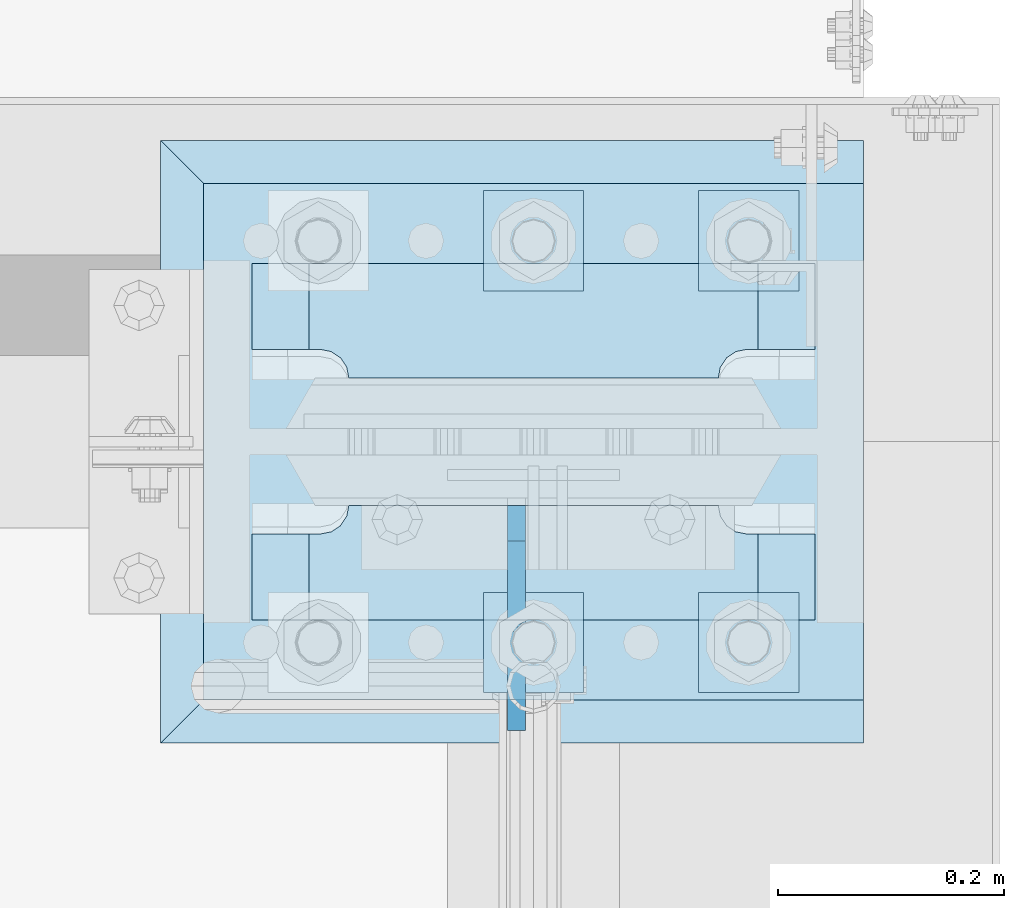
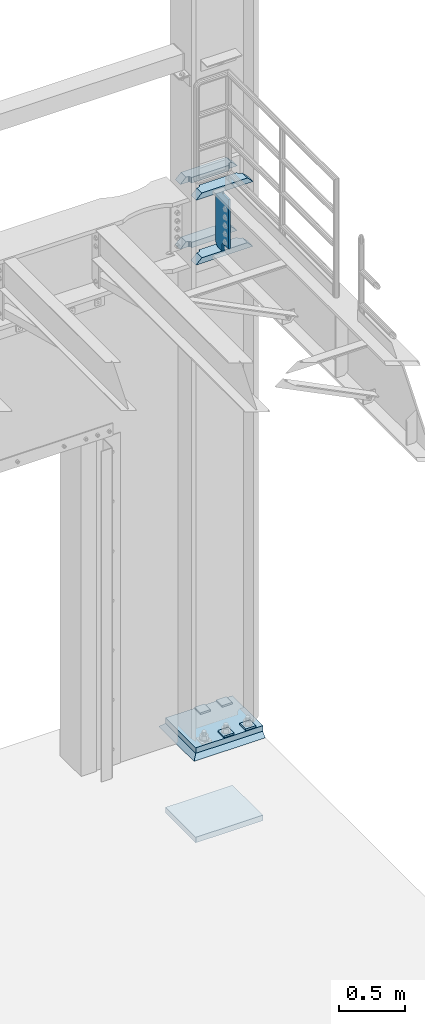
# One storey, part 1830 of 1876: 12 plates, 3 elements without a shape of their own.
"""IFC2X3 building model written with IfcOpenShell, lengths in millimetres."""

from ifc_helpers import new_model, si_unit, frame, origin_with_axes, place, context, subcontext, project, spatial, faceted_brep, material, type_object, element, aggregate, save


model = new_model("IFC2X3")

# Units and contexts
model_context = context("Model", 3, precision=1e-05, world=origin_with_axes())
body_context = subcontext(model_context, "Body", "Model", "MODEL_VIEW")
ifc_project = project(units=[si_unit("LENGTHUNIT", "METRE", prefix="MILLI"), si_unit("AREAUNIT", "SQUARE_METRE"), si_unit("VOLUMEUNIT", "CUBIC_METRE"), si_unit("MASSUNIT", "GRAM", prefix="KILO"), si_unit("TIMEUNIT", "SECOND"), si_unit("PLANEANGLEUNIT", "RADIAN"), si_unit("SOLIDANGLEUNIT", "STERADIAN"), si_unit("THERMODYNAMICTEMPERATUREUNIT", "DEGREE_CELSIUS"), si_unit("LUMINOUSINTENSITYUNIT", "LUMEN")], contexts=[model_context])

# Site, building, storey
site_placement = place(None, origin_with_axes())
site = spatial("IfcSite", under=ifc_project, at=site_placement, CompositionType="ELEMENT")
building_placement = place(site_placement, origin_with_axes())
building = spatial("IfcBuilding", under=site, at=building_placement, Name="Undefined", CompositionType="ELEMENT")
storey_placement = place(building_placement, origin_with_axes())
storey = spatial("IfcBuildingStorey", under=building, at=storey_placement, Name="Undefined", CompositionType="ELEMENT", Elevation=0.0)

# Assembly, plate
assembly_1_placement = place(storey_placement, origin_with_axes())
assembly_1 = element("IfcElementAssembly", 1, at=assembly_1_placement, inside=storey, Name="GROUT", AssemblyPlace="NOTDEFINED", PredefinedType="REINFORCEMENT_UNIT")
ifc_material_1 = material(Name="CONCRETE/Concrete_Undefined")
plate_type_1 = type_object("IfcPlateType", PredefinedType="NOTDEFINED")
plate_1_placement = place(assembly_1_placement, frame((7289.8, 13449.3, 19.05), z_axis=(0.0, 1.0, 0.0), x_axis=(1.0, 0.0, 0.0)))
plate_1 = element("IfcPlate", 2, at=plate_1_placement, type_object=plate_type_1, material=ifc_material_1, Name="GROUT", context=body_context, shape_type="Brep", body=[
    faceted_brep([(622.299804676334, 19.0499984735558, 533.400024414062), (622.299999999999, -19.05, 495.299999999985), (622.299999999984, -19.05, 38.1000000000167), (622.299804676334, 19.05, 0.0), (38.100000011611, -19.05, 495.299999988873), (-2.72848410531878e-12, 19.05, 533.400024414152), (-9.09494701772928e-13, 19.05, -1.81898940354586e-12), (38.1000000120275, -19.05, 38.1000000109725)], [[[0, 1, 2, 3]], [[4, 5, 6, 7]], [[6, 5, 0, 3]], [[7, 6, 3, 2]], [[2, 1, 4, 7]], [[5, 4, 1, 0]]]),
])
aggregate(assembly_1, [plate_1])

# Assembly, plates
assembly_2_placement = place(storey_placement, origin_with_axes())
assembly_2 = element("IfcElementAssembly", 3, at=assembly_2_placement, inside=storey, Name="COLUMN", AssemblyPlace="NOTDEFINED", PredefinedType="RIGID_FRAME")
ifc_material_2 = material(Name="STEEL/A572-50")
plate_type_2 = type_object("IfcPlateType", PredefinedType="NOTDEFINED")
plate_2_placement = place(assembly_2_placement, frame((7370.7625, 13772.35625, 4508.50002441406), z_axis=(1.0, 0.0, 0.0), x_axis=(0.0, 1.0, 0.0)))
plate_2 = element("IfcPlate", 4, at=plate_2_placement, type_object=plate_type_2, material=ifc_material_2, Name="PLATE", context=body_context, shape_type="Brep", body=[
    faceted_brep([(101.599998474121, -25.3999999999996, 498.475006103516), (101.599998474121, 25.3999999999996, 447.975004579813), (25.3999996185303, 25.3999999999996, 447.975004579813), (25.3999996185303, -25.3999999999996, 498.475006103516), (23.4665397733534, -25.3999999999996, 428.429848211837), (25.3999996185303, -25.3999999999996, 438.150007247925), (25.3999996185303, 25.3999999999996, 438.150007247925), (23.4665397733534, 25.3999999999996, 428.429848211837), (17.9605119723965, -25.3999999999996, 420.189495275529), (17.9605119723965, 25.3999999999996, 420.189495275529), (9.72015903608917, -25.3999999999996, 414.683467474573), (9.72015903608917, 25.3999999999996, 414.683467474573), (0.0, -25.3999999999996, 412.750007629395), (0.0, 25.3999999999996, 412.750007629395), (0.0, -25.3999999999996, 85.7249984741211), (0.0, 25.3999999999996, 85.7249984741211), (9.72015903609099, -25.3999999999996, 83.7915386289451), (9.72015903609099, 25.3999999999996, 83.7915386289451), (17.9605119723983, -25.3999999999996, 78.2855108279891), (17.9605119723983, 25.3999999999996, 78.2855108279891), (23.4665397733552, -25.3999999999996, 70.0451578916818), (23.4665397733552, 25.3999999999996, 70.0451578916818), (25.3999996185303, -25.3999999999996, 60.3249988555908), (25.3999996185303, 25.3999999999996, 60.3249988555908), (25.3999996185303, 25.3999999999996, 50.5000015237028), (25.3999996185303, -25.3999999999996, 0.0), (101.599998474121, 25.3999999999996, 50.5000015237028), (101.599998474121, -25.3999999999996, 0.0)], [[[0, 1, 2, 3]], [[4, 5, 6, 7]], [[8, 4, 7, 9]], [[10, 8, 9, 11]], [[12, 10, 11, 13]], [[14, 12, 13, 15]], [[16, 14, 15, 17]], [[18, 16, 17, 19]], [[20, 18, 19, 21]], [[22, 20, 21, 23]], [[22, 23, 24, 25]], [[26, 27, 25, 24]], [[5, 4, 8, 10, 12, 14, 16, 18, 20, 22, 25, 27, 0, 3]], [[6, 5, 3, 2]], [[26, 24, 23, 21, 19, 17, 15, 13, 11, 9, 7, 6, 2, 1]], [[27, 26, 1, 0]]]),
])
plate_3_placement = place(assembly_2_placement, frame((7370.7625, 13772.35625, 5105.4), z_axis=(1.0, 0.0, 0.0), x_axis=(0.0, 1.0, 0.0)))
plate_3 = element("IfcPlate", 5, at=plate_3_placement, type_object=plate_type_2, material=ifc_material_2, Name="PLATE", context=body_context, shape_type="Brep", body=[
    faceted_brep([(101.599998474121, -25.3999999999996, 498.475006103516), (101.599998474121, 25.3999999999996, 447.975004579813), (25.3999996185303, 25.3999999999996, 447.975004579813), (25.3999996185303, -25.3999999999996, 498.475006103516), (23.4665397733534, -25.3999999999996, 428.429848211837), (25.3999996185303, -25.3999999999996, 438.150007247925), (25.3999996185303, 25.3999999999996, 438.150007247925), (23.4665397733534, 25.3999999999996, 428.429848211837), (17.9605119723965, -25.3999999999996, 420.189495275529), (17.9605119723965, 25.3999999999996, 420.189495275529), (9.72015903608917, -25.3999999999996, 414.683467474573), (9.72015903608917, 25.3999999999996, 414.683467474573), (0.0, -25.3999999999996, 412.750007629395), (0.0, 25.3999999999996, 412.750007629395), (0.0, -25.3999999999996, 85.7249984741211), (0.0, 25.3999999999996, 85.7249984741211), (9.72015903609099, -25.3999999999996, 83.7915386289451), (9.72015903609099, 25.3999999999996, 83.7915386289451), (17.9605119723983, -25.3999999999996, 78.2855108279891), (17.9605119723983, 25.3999999999996, 78.2855108279891), (23.4665397733552, -25.3999999999996, 70.0451578916818), (23.4665397733552, 25.3999999999996, 70.0451578916818), (25.3999996185303, -25.3999999999996, 60.3249988555908), (25.3999996185303, 25.3999999999996, 60.3249988555908), (25.3999996185303, 25.3999999999996, 50.5000015237028), (25.3999996185303, -25.3999999999996, 0.0), (101.599998474121, 25.3999999999996, 50.5000015237028), (101.599998474121, -25.3999999999996, 0.0)], [[[0, 1, 2, 3]], [[4, 5, 6, 7]], [[8, 4, 7, 9]], [[10, 8, 9, 11]], [[12, 10, 11, 13]], [[14, 12, 13, 15]], [[16, 14, 15, 17]], [[18, 16, 17, 19]], [[20, 18, 19, 21]], [[22, 20, 21, 23]], [[22, 23, 24, 25]], [[26, 27, 25, 24]], [[5, 4, 8, 10, 12, 14, 16, 18, 20, 22, 25, 27, 0, 3]], [[6, 5, 3, 2]], [[26, 24, 23, 21, 19, 17, 15, 13, 11, 9, 7, 6, 2, 1]], [[27, 26, 1, 0]]]),
])
plate_4_placement = place(assembly_2_placement, frame((7370.7625, 13558.04375, 4508.50002441406), z_axis=(1.0, 0.0, 0.0), x_axis=(0.0, 1.0, 0.0)))
plate_4 = element("IfcPlate", 6, at=plate_4_placement, type_object=plate_type_2, material=ifc_material_2, Name="PLATE", context=body_context, shape_type="Brep", body=[
    faceted_brep([(76.1999988555908, -25.3999999999996, 498.475006103516), (76.1999988555908, 25.3999999999996, 447.975004579812), (0.0, 25.3999999999996, 447.975004579812), (0.0, -25.3999999999996, 498.475006103516), (76.1999988555908, 25.3999999999996, 50.5000015237032), (76.1999988555908, -25.3999999999996, 0.0), (0.0, -25.3999996185375, 0.0), (0.0, 25.3999999999996, 50.5000015237032), (76.1999988555908, 25.3999999999996, 60.3249988555908), (76.1999988555908, -25.3999999999996, 60.3249988555908), (78.1334587007668, -25.3999999999996, 70.045157891682), (78.1334587007668, 25.3999999999996, 70.045157891682), (83.6394865017228, -25.3999999999996, 78.2855108279893), (83.6394865017228, 25.3999999999996, 78.2855108279893), (91.8798394380301, -25.3999999999996, 83.7915386289454), (91.8798394380301, 25.3999999999996, 83.7915386289454), (101.599998474121, -25.3999999999996, 85.7249984741211), (101.599998474121, 25.3999999999996, 85.7249984741211), (101.599998474121, -25.3999999999996, 412.750007629395), (101.599998474121, 25.3999999999996, 412.750007629395), (91.8798394380301, -25.3999999999996, 414.68346747457), (91.8798394380301, 25.3999999999996, 414.68346747457), (83.6394865017219, -25.3999999999996, 420.189495275526), (83.6394865017219, 25.3999999999996, 420.189495275526), (78.1334587007659, -25.3999999999996, 428.429848211834), (78.1334587007659, 25.3999999999996, 428.429848211834), (76.1999988555908, -25.3999999999996, 438.150007247925), (76.1999988555908, 25.3999999999996, 438.150007247925)], [[[0, 1, 2, 3]], [[4, 5, 6, 7]], [[8, 9, 5, 4]], [[10, 9, 8, 11]], [[12, 10, 11, 13]], [[14, 12, 13, 15]], [[16, 14, 15, 17]], [[18, 16, 17, 19]], [[20, 18, 19, 21]], [[22, 20, 21, 23]], [[24, 22, 23, 25]], [[26, 24, 25, 27]], [[6, 5, 9, 10, 12, 14, 16, 18, 20, 22, 24, 26, 0, 3]], [[7, 6, 3, 2]], [[27, 25, 23, 21, 19, 17, 15, 13, 11, 8, 4, 7, 2, 1]], [[26, 27, 1, 0]]]),
])
plate_5_placement = place(assembly_2_placement, frame((7370.7625, 13558.04375, 5105.4), z_axis=(1.0, 0.0, 0.0), x_axis=(0.0, 1.0, 0.0)))
plate_5 = element("IfcPlate", 7, at=plate_5_placement, type_object=plate_type_2, material=ifc_material_2, Name="PLATE", context=body_context, shape_type="Brep", body=[
    faceted_brep([(76.1999988555908, -25.3999999999996, 498.475006103516), (76.1999988555908, 25.3999999999996, 447.975004579812), (0.0, 25.3999999999996, 447.975004579812), (0.0, -25.3999999999996, 498.475006103516), (76.1999988555908, 25.3999999999996, 50.5000015237032), (76.1999988555908, -25.3999999999996, 0.0), (0.0, -25.3999996185375, 0.0), (0.0, 25.3999999999996, 50.5000015237032), (76.1999988555908, 25.3999999999996, 60.3249988555908), (76.1999988555908, -25.3999999999996, 60.3249988555908), (78.1334587007668, -25.3999999999996, 70.045157891682), (78.1334587007668, 25.3999999999996, 70.045157891682), (83.6394865017228, -25.3999999999996, 78.2855108279893), (83.6394865017228, 25.3999999999996, 78.2855108279893), (91.8798394380301, -25.3999999999996, 83.7915386289454), (91.8798394380301, 25.3999999999996, 83.7915386289454), (101.599998474121, -25.3999999999996, 85.7249984741211), (101.599998474121, 25.3999999999996, 85.7249984741211), (101.599998474121, -25.3999999999996, 412.750007629395), (101.599998474121, 25.3999999999996, 412.750007629395), (91.8798394380301, -25.3999999999996, 414.68346747457), (91.8798394380301, 25.3999999999996, 414.68346747457), (83.6394865017219, -25.3999999999996, 420.189495275526), (83.6394865017219, 25.3999999999996, 420.189495275526), (78.1334587007659, -25.3999999999996, 428.429848211834), (78.1334587007659, 25.3999999999996, 428.429848211834), (76.1999988555908, -25.3999999999996, 438.150007247925), (76.1999988555908, 25.3999999999996, 438.150007247925)], [[[0, 1, 2, 3]], [[4, 5, 6, 7]], [[8, 9, 5, 4]], [[10, 9, 8, 11]], [[12, 10, 11, 13]], [[14, 12, 13, 15]], [[16, 14, 15, 17]], [[18, 16, 17, 19]], [[20, 18, 19, 21]], [[22, 20, 21, 23]], [[24, 22, 23, 25]], [[26, 24, 25, 27]], [[6, 5, 9, 10, 12, 14, 16, 18, 20, 22, 24, 26, 0, 3]], [[7, 6, 3, 2]], [[27, 25, 23, 21, 19, 17, 15, 13, 11, 8, 4, 7, 2, 1]], [[26, 27, 1, 0]]]),
])
ifc_material_3 = material(Name="STEEL/A36")
plate_type_3 = type_object("IfcPlateType", PredefinedType="NOTDEFINED")
plate_6_placement = place(assembly_2_placement, frame((7604.91949987411, 13659.64375, 5080.0), z_axis=(0.0, -1.0, 0.0), x_axis=(0.0, 0.0, -1.0)))
plate_6 = element("IfcPlate", 8, at=plate_6_placement, type_object=plate_type_3, material=ifc_material_3, Name="PLATE", context=body_context, shape_type="Brep", body=[
    faceted_brep([(469.900012207031, -7.9375, 199.231247384208), (469.900012207031, -7.9375, 116.681246757507), (469.900012207031, 7.9375, 116.681246757507), (469.900012207031, 7.9375, 199.231246948242), (470.866742129619, -7.9375, 111.821167239462), (470.866742129619, 7.9375, 111.821167239462), (473.619756030097, -7.9375, 107.700990771308), (473.619756030097, 7.9375, 107.700990771308), (477.739932498251, -7.9375, 104.94797687083), (477.739932498251, 7.9375, 104.94797687083), (482.600012016296, -7.9375, 103.981246948242), (482.600012016296, 7.9375, 103.981246948242), (546.099975585938, -7.9375, 103.981246948242), (546.099975585938, 7.9375, 103.981246948242), (12.6999996185305, -7.9375, 199.231249999999), (12.6999996185305, 7.9375, 199.231246948242), (12.6999996185305, 7.9375, 116.681249809264), (12.6999996185305, -7.9375, 116.681249809264), (11.7332696959429, 7.9375, 111.821170291219), (11.7332696959429, -7.9375, 111.821170291219), (8.98025579546447, 7.9375, 107.700993823065), (8.98025579546447, -7.9375, 107.700993823065), (4.86007932731081, 7.9375, 104.947979922586), (4.86007932731081, -7.9375, 104.947979922586), (0.0, 7.9375, 103.981249999999), (0.0, -7.9375, 103.981249999999), (0.0, 7.93749999999999, 31.75), (0.0, -7.93749999999998, 31.75), (31.75, -7.93749999999998, 0.0), (31.75, 7.93749999999999, 0.0), (514.349975585938, -7.9375, 0.0), (514.349975585938, 7.9375, 0.0), (546.099975585938, -7.9375, 31.75), (546.099975585938, 7.9375, 31.75)], [[[0, 1, 2, 3]], [[4, 5, 2, 1]], [[6, 7, 5, 4]], [[8, 9, 7, 6]], [[10, 11, 9, 8]], [[12, 13, 11, 10]], [[14, 15, 16, 17]], [[17, 16, 18, 19]], [[19, 18, 20, 21]], [[21, 20, 22, 23]], [[23, 22, 24, 25]], [[26, 27, 25, 24]], [[28, 27, 26, 29]], [[30, 28, 29, 31]], [[32, 30, 31, 33]], [[8, 6, 4, 1, 0, 14, 17, 19, 21, 23, 25, 27, 28, 30, 32, 12, 10]], [[15, 14, 0, 3]], [[33, 31, 29, 26, 24, 22, 20, 18, 16, 15, 3, 2, 5, 7, 9, 11, 13]], [[32, 33, 13, 12]]]),
])

assembly_3_placement = place(storey_placement, origin_with_axes())
assembly_3 = element("IfcElementAssembly", 9, at=assembly_3_placement, inside=storey, Name="TEMPLATE", AssemblyPlace="NOTDEFINED", PredefinedType="RIGID_FRAME")
plate_type_4 = type_object("IfcPlateType", PredefinedType="NOTDEFINED")
plate_7_placement = place(assembly_3_placement, frame((7766.05, 13582.65, 96.8375), z_axis=(0.0, -1.0, 0.0), x_axis=(1.0, 0.0, 0.0)))
plate_7 = element("IfcPlate", 10, at=plate_7_placement, type_object=plate_type_4, material=ifc_material_2, Name="PLATE WASHER", context=body_context, shape_type="Brep", body=[
    faceted_brep([(0.0, -7.9375, 0.0), (0.0, -7.9375, 88.9000015258789), (0.0, 7.9375, 88.9000015258789), (0.0, 7.9375, 0.0), (88.9000015258789, -7.9375, 88.9000015258789), (88.9000015258789, 7.9375, 88.9000015258789), (88.9000015258789, -7.9375, 0.0), (88.9000015258789, 7.9375, 0.0)], [[[0, 1, 2, 3]], [[1, 4, 5, 2]], [[4, 6, 7, 5]], [[6, 0, 3, 7]], [[5, 7, 3, 2]], [[6, 4, 1, 0]]]),
])
plate_8_placement = place(assembly_3_placement, frame((7766.05, 13938.25, 96.8375), z_axis=(0.0, -1.0, 0.0), x_axis=(1.0, 0.0, 0.0)))
plate_8 = element("IfcPlate", 11, at=plate_8_placement, type_object=plate_type_4, material=ifc_material_2, Name="PLATE WASHER", context=body_context, shape_type="Brep", body=[
    faceted_brep([(0.0, -7.9375, 0.0), (0.0, -7.9375, 88.9000015258789), (0.0, 7.9375, 88.9000015258789), (0.0, 7.9375, 0.0), (88.9000015258789, -7.9375, 88.9000015258789), (88.9000015258789, 7.9375, 88.9000015258789), (88.9000015258789, -7.9375, 0.0), (88.9000015258789, 7.9375, 0.0)], [[[0, 1, 2, 3]], [[1, 4, 5, 2]], [[4, 6, 7, 5]], [[6, 0, 3, 7]], [[5, 7, 3, 2]], [[6, 4, 1, 0]]]),
])
plate_9_placement = place(assembly_3_placement, frame((7575.55, 13582.65, 96.8375), z_axis=(0.0, -1.0, 0.0), x_axis=(1.0, 0.0, 0.0)))
plate_9 = element("IfcPlate", 12, at=plate_9_placement, type_object=plate_type_4, material=ifc_material_2, Name="PLATE WASHER", context=body_context, shape_type="Brep", body=[
    faceted_brep([(0.0, -7.9375, 0.0), (0.0, -7.9375, 88.9000015258789), (0.0, 7.9375, 88.9000015258789), (0.0, 7.9375, 0.0), (88.9000015258789, -7.9375, 88.9000015258789), (88.9000015258789, 7.9375, 88.9000015258789), (88.9000015258789, -7.9375, 0.0), (88.9000015258789, 7.9375, 0.0)], [[[0, 1, 2, 3]], [[1, 4, 5, 2]], [[4, 6, 7, 5]], [[6, 0, 3, 7]], [[5, 7, 3, 2]], [[6, 4, 1, 0]]]),
])
plate_10_placement = place(assembly_3_placement, frame((7575.55, 13938.25, 96.8375), z_axis=(0.0, -1.0, 0.0), x_axis=(1.0, 0.0, 0.0)))
plate_10 = element("IfcPlate", 13, at=plate_10_placement, type_object=plate_type_4, material=ifc_material_2, Name="PLATE WASHER", context=body_context, shape_type="Brep", body=[
    faceted_brep([(0.0, -7.9375, 0.0), (0.0, -7.9375, 88.9000015258789), (0.0, 7.9375, 88.9000015258789), (0.0, 7.9375, 0.0), (88.9000015258789, -7.9375, 88.9000015258789), (88.9000015258789, 7.9375, 88.9000015258789), (88.9000015258789, -7.9375, 0.0), (88.9000015258789, 7.9375, 0.0)], [[[0, 1, 2, 3]], [[1, 4, 5, 2]], [[4, 6, 7, 5]], [[6, 0, 3, 7]], [[5, 7, 3, 2]], [[6, 4, 1, 0]]]),
])
plate_type_5 = type_object("IfcPlateType", PredefinedType="NOTDEFINED")
plate_11_placement = place(assembly_3_placement, frame((7327.9, 13487.4, -762.0), z_axis=(0.0, 1.0, 0.0), x_axis=(1.0, 0.0, 0.0)))
plate_11 = element("IfcPlate", 14, at=plate_11_placement, type_object=plate_type_5, material=ifc_material_2, Name="PLATE", context=body_context, shape_type="Brep", body=[
    faceted_brep([(0.0, -25.3999996185375, 0.0), (0.0, -25.4, 457.200012207031), (0.0, 25.4, 457.200012207031), (0.0, 25.3999996185339, 9.09494701772928e-13), (584.200012207031, -25.4, 457.200012207031), (584.200012207031, 25.4, 457.200012207031), (584.200012207031, -25.4, 0.0), (584.200012207031, 25.4, 0.0)], [[[0, 1, 2, 3]], [[1, 4, 5, 2]], [[4, 6, 7, 5]], [[6, 0, 3, 7]], [[5, 7, 3, 2]], [[6, 4, 1, 0]]]),
])
aggregate(assembly_3, [plate_11, plate_7, plate_8, plate_9, plate_10])

# Plate
ifc_material_4 = material(Name="STEEL/A572-GR.50")
plate_12_placement = place(assembly_2_placement, frame((7327.9, 13487.4, 63.5), z_axis=(0.0, 1.0, 0.0), x_axis=(1.0, 0.0, 0.0)))
plate_12 = element("IfcPlate", 15, at=plate_12_placement, type_object=plate_type_5, material=ifc_material_4, Name="PLATE", context=body_context, shape_type="Brep", body=[
    faceted_brep([(0.0, -25.3999996185375, 0.0), (0.0, -25.4, 457.200012207031), (0.0, 25.4, 457.200012207031), (0.0, 25.3999996185339, 9.09494701772928e-13), (584.200012207031, -25.4, 457.200012207031), (584.200012207031, 25.4, 457.200012207031), (584.200012207031, -25.4, 0.0), (584.200012207031, 25.4, 0.0)], [[[0, 1, 2, 3]], [[1, 4, 5, 2]], [[4, 6, 7, 5]], [[6, 0, 3, 7]], [[5, 7, 3, 2]], [[6, 4, 1, 0]]]),
])

aggregate(assembly_2, [plate_2, plate_3, plate_4, plate_5, plate_6, plate_12])

save(model, "model.ifc")
